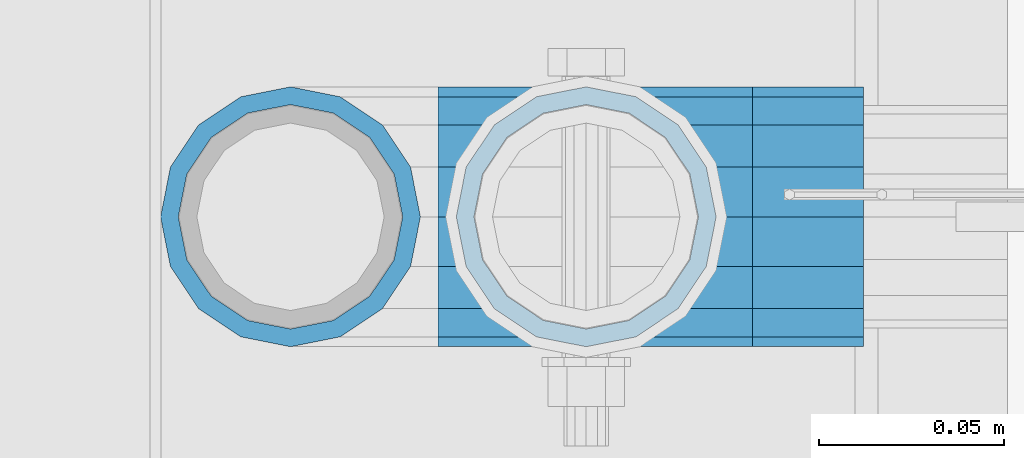
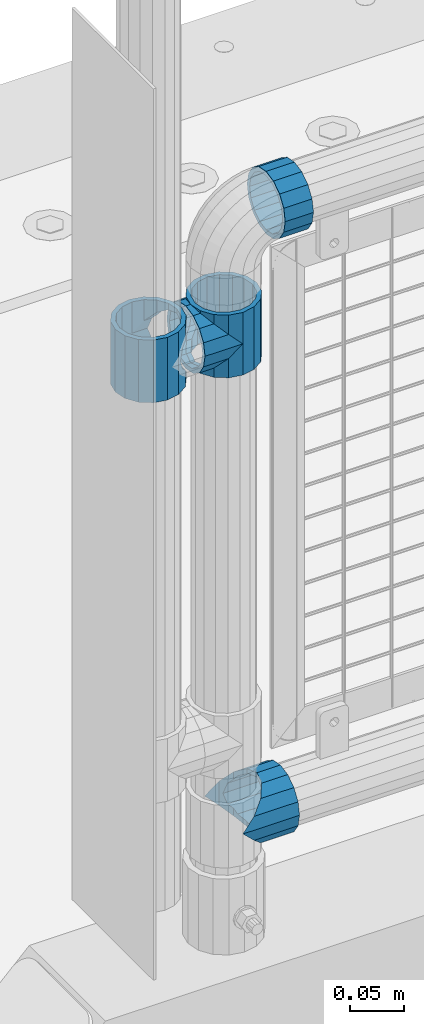
# One storey, part 159 of 270: 5 beams.
"""IFC2X3 building model written with IfcOpenShell, lengths in millimetres."""

from ifc_helpers import new_model, si_unit, frame, origin_with_axes, place, context, subcontext, project, spatial, faceted_brep, material, type_object, element, save


model = new_model("IFC2X3")

# Units and contexts
model_context = context("Model", 3, precision=1e-05, world=origin_with_axes())
body_context = subcontext(model_context, "Body", "Model", "MODEL_VIEW")
ifc_project = project(units=[si_unit("LENGTHUNIT", "METRE", prefix="MILLI"), si_unit("AREAUNIT", "SQUARE_METRE"), si_unit("VOLUMEUNIT", "CUBIC_METRE"), si_unit("MASSUNIT", "GRAM", prefix="KILO"), si_unit("TIMEUNIT", "SECOND"), si_unit("PLANEANGLEUNIT", "RADIAN"), si_unit("SOLIDANGLEUNIT", "STERADIAN"), si_unit("THERMODYNAMICTEMPERATUREUNIT", "DEGREE_CELSIUS"), si_unit("LUMINOUSINTENSITYUNIT", "LUMEN")], contexts=[model_context])

# Site, building, storey
site_placement = place(None, origin_with_axes())
site = spatial("IfcSite", under=ifc_project, at=site_placement, CompositionType="ELEMENT")
building_placement = place(site_placement, origin_with_axes())
building = spatial("IfcBuilding", under=site, at=building_placement, Name="Standard", CompositionType="ELEMENT")
storey_placement = place(building_placement, origin_with_axes())
storey = spatial("IfcBuildingStorey", under=building, at=storey_placement, Name="Undefined", CompositionType="ELEMENT", Elevation=0.0)

# Beams
ifc_material = material(Name="Misc_Undefined")
beam_type = type_object("IfcBeamType", PredefinedType="NOTDEFINED")
beam_1_placement = place(storey_placement, frame((621.0, -16335.5, 848.670000000001), z_axis=(0.0, 1.0, 0.0), x_axis=(-1.0, 0.0, 0.0)))
element("IfcBeam", 1, at=beam_1_placement, inside=storey, type_object=beam_type, material=ifc_material, context=body_context, shape_type="Brep", body=[
    faceted_brep([(0.0, 0.0, -35.1499999999996), (13.4513226476338, -13.4513226476329, -32.4743655677721), (13.4513226476338, 13.4513226476329, -32.4743655677721), (32.4743655677703, -26.8123795176775, 13.4513226476338), (32.4743655677703, -32.4743655677717, 13.4513226476338), (24.8548033587067, -24.8548033587072, 24.8548033587067), (24.8548033587067, -16.3810424080045, 24.8548033587067), (27.1226768591041, -21.4606908090117, 21.4606908090118), (35.1500000000015, -30.35, 0.0), (35.1500000000015, -35.15, 0.0), (32.8397438117208, -28.0397438117175, 11.6144421722802), (32.8397438117172, -28.0397438117175, -11.6144421722802), (32.4743655677703, -26.8123795176776, -13.4513226476338), (32.4743655677703, -32.4743655677717, -13.4513226476338), (27.1226768591041, -21.4606908090117, -21.4606908090118), (24.8548033587067, -16.3810424080045, -24.8548033587067), (24.8548033587067, -24.8548033587072, -24.8548033587067), (20.0882031229849, -11.6144421722805, -28.0397438117179), (16.6306603983721, 0.0, -30.3500000000004), (20.0882031229849, 11.6144421722805, -28.0397438117179), (24.8548033587067, 16.3810424080045, -24.8548033587067), (24.8548033587067, 24.8548033587072, -24.8548033587067), (27.1226768591041, 21.4606908090117, -21.4606908090118), (32.4743655677703, 26.8123795176775, -13.4513226476338), (32.4743655677703, 32.4743655677717, -13.4513226476338), (32.8397438117172, 28.0397438117175, -11.6144421722802), (35.1500000000015, 30.35, 0.0), (35.1500000000015, 35.1500000000003, 0.0), (32.8397438117208, 28.0397438117175, 11.6144421722802), (32.4743655677703, 26.8123795176776, 13.4513226476338), (32.4743655677703, 32.4743655677717, 13.4513226476338), (27.1226768591041, 21.4606908090117, 21.4606908090118), (24.8548033587067, 16.3810424080045, 24.8548033587067), (24.8548033587067, 24.8548033587072, 24.8548033587067), (13.4513226476338, 13.4513226476329, 32.4743655677721), (13.4513226476338, -13.4513226476329, 32.4743655677721), (0.0, 0.0, 35.1499999999996), (20.0882031229812, 11.6144421722805, 28.0397438117179), (16.6306603983612, 0.0, 30.3500000000004), (20.0882031229812, -11.6144421722805, 28.0397438117179), (40.1500000000015, -35.15, 0.0), (40.1500000000015, -32.4743655677717, 13.4513226476338), (40.1500000000015, -24.8548033587072, 24.8548033587067), (40.1500000000015, -13.4513226476329, 32.4743655677721), (40.1500000000015, 0.0, 35.1499999999996), (40.1500000000015, -24.8548033587072, -24.8548033587067), (40.1500000000015, -32.4743655677717, -13.4513226476338), (40.1500000000015, -13.4513226476329, -32.4743655677721), (40.1500000000015, 0.0, -35.1499999999996), (40.1500000000015, 13.4513226476329, -32.4743655677721), (40.1500000000015, 24.8548033587072, -24.8548033587067), (40.1500000000015, 32.4743655677717, -13.4513226476338), (40.1500000000015, 35.15, 0.0), (40.1500000000015, 32.4743655677717, 13.4513226476338), (40.1500000000015, 24.8548033587072, 24.8548033587067), (40.1500000000015, 13.4513226476329, 32.4743655677721), (40.1500000000015, -21.4606908090117, 21.4606908090118), (40.1500000000015, -11.6144421722805, 28.0397438117179), (40.1500000000015, 0.0, 30.3500000000004), (40.1500000000015, 11.6144421722805, 28.0397438117179), (40.1500000000015, 21.4606908090117, 21.4606908090118), (40.1500000000015, 28.0397438117175, 11.6144421722802), (40.1500000000015, 30.35, 0.0), (40.1500000000015, 28.0397438117175, -11.6144421722802), (40.1500000000015, 21.4606908090117, -21.4606908090118), (40.1500000000015, 11.6144421722805, -28.0397438117179), (40.1500000000015, 0.0, -30.3500000000004), (40.1500000000015, -11.6144421722805, -28.0397438117179), (40.1500000000015, -21.4606908090117, -21.4606908090118), (40.1500000000015, -28.0397438117175, -11.6144421722802), (40.1500000000015, -30.35, 0.0), (40.1500000000015, -28.0397438117175, 11.6144421722802)], [[[0, 1, 2]], [[3, 4, 5, 6, 7]], [[8, 9, 4, 3, 10]], [[11, 12, 13, 9, 8]], [[14, 15, 16, 13, 12]], [[2, 1, 16, 15, 17, 18, 19, 20, 21]], [[21, 20, 22, 23, 24]], [[24, 23, 25, 26, 27]], [[27, 26, 28, 29, 30]], [[30, 29, 31, 32, 33]], [[34, 35, 36]], [[33, 32, 37, 38, 39, 6, 5, 35, 34]], [[40, 41, 4, 9]], [[41, 42, 5, 4]], [[42, 43, 35, 5]], [[43, 44, 36, 35]], [[45, 46, 13, 16]], [[47, 45, 16, 1]], [[48, 47, 1, 0]], [[49, 48, 0, 2]], [[50, 49, 2, 21]], [[51, 50, 21, 24]], [[52, 51, 24, 27]], [[53, 52, 27, 30]], [[54, 53, 30, 33]], [[55, 54, 33, 34]], [[44, 55, 34, 36]], [[46, 40, 9, 13]], [[45, 47, 48, 49, 50, 51, 52, 53, 54, 55, 44, 43, 42, 41, 40, 46], [56, 57, 58, 59, 60, 61, 62, 63, 64, 65, 66, 67, 68, 69, 70, 71]], [[59, 58, 38, 37]], [[60, 59, 37, 32, 31]], [[61, 60, 31, 29, 28]], [[62, 61, 28, 26]], [[63, 62, 26, 25]], [[22, 64, 63, 25, 23]], [[19, 65, 64, 22, 20]], [[66, 65, 19, 18]], [[67, 66, 18, 17]], [[68, 67, 17, 15, 14]], [[69, 68, 14, 12, 11]], [[70, 69, 11, 8]], [[71, 70, 8, 10]], [[7, 56, 71, 10, 3]], [[39, 57, 56, 7, 6]], [[58, 57, 39, 38]]]),
])
beam_2_placement = place(storey_placement, frame((541.0, -16335.5, 883.82), z_axis=(-1.0, 0.0, 0.0), x_axis=(0.0, 0.0, -1.0)))
element("IfcBeam", 2, at=beam_2_placement, inside=storey, type_object=beam_type, material=ifc_material, context=body_context, shape_type="Brep", body=[
    faceted_brep([(7.11025618828319, -11.6144421722802, -32.8397438117172), (7.11025618828319, -11.6144421722802, -28.0397438117179), (13.689309190989, -21.4606908090118, -21.46069080901), (13.689309190989, -21.4606908090118, -27.1226768591041), (8.33762048232484, -13.4513226476338, -32.4743655677703), (23.5355578277203, -28.0397438117179, -11.614442172282), (23.5355578277203, -28.0397438117179, -20.0882031229885), (18.7689575919954, -24.8548033587067, -24.8548033587067), (35.1500000000015, -30.35, 0.0), (35.1500000000008, -30.3500000000004, -16.6306603983721), (46.7644421722812, -28.0397438117179, -11.614442172282), (46.7644421722812, -28.0397438117179, -20.0882031229885), (51.5310424080071, -24.8548033587067, -24.8548033587067), (56.6106908090125, -21.4606908090118, -21.46069080901), (56.6106908090125, -21.4606908090118, -27.1226768591041), (61.9623795176767, -13.4513226476338, -32.4743655677703), (63.1897438117183, -11.6144421722802, -28.0397438117179), (63.1897438117183, -11.6144421722802, -32.8397438117172), (65.5000000000008, 0.0, -30.3499999999985), (65.5000000000008, 0.0, -35.1500000000015), (63.1897438117183, 11.6144421722802, -28.0397438117179), (63.1897438117183, 11.6144421722802, -32.8397438117208), (56.6106908090125, 21.4606908090118, -21.46069080901), (56.6106908090125, 21.4606908090118, -27.1226768591005), (61.9623795176767, 13.4513226476338, -32.4743655677703), (46.7644421722812, 28.0397438117179, -11.614442172282), (46.7644421722812, 28.0397438117179, -20.0882031229812), (51.5310424080071, 24.8548033587067, -24.8548033587067), (35.1500000000015, 30.35, 0.0), (35.1500000000008, 30.3500000000004, -16.6306603983612), (23.5355578277203, 28.0397438117179, -11.614442172282), (23.5355578277203, 28.0397438117179, -20.0882031229812), (18.7689575919954, 24.8548033587067, -24.8548033587067), (13.689309190989, 21.4606908090118, -21.46069080901), (13.689309190989, 21.4606908090118, -27.1226768591005), (8.33762048232484, 13.4513226476338, -32.4743655677703), (7.11025618828324, 11.6144421722802, -28.0397438117179), (7.11025618828324, 11.6144421722802, -32.8397438117208), (4.80000000000075, 0.0, -30.3499999999985), (4.80000000000075, 0.0, -35.1500000000015), (0.0, 21.4606908090118, 21.46069080901), (0.0, 28.0397438117179, 11.614442172282), (70.2999999999993, 28.0397438117179, 11.614442172282), (70.2999999999993, 21.4606908090118, 21.46069080901), (0.0, 11.6144421722802, 28.0397438117179), (70.2999999999993, 11.6144421722802, 28.0397438117179), (0.0, 0.0, 30.3499999999985), (70.2999999999993, 0.0, 30.3499999999985), (0.0, -11.6144421722802, 28.0397438117179), (70.2999999999993, -11.6144421722802, 28.0397438117179), (0.0, -21.4606908090118, 21.46069080901), (70.2999999999993, -21.4606908090118, 21.46069080901), (0.0, -28.0397438117179, 11.614442172282), (70.2999999999993, -28.0397438117179, 11.614442172282), (0.0, -24.8548033587067, -24.8548033587067), (0.0, -13.4513226476338, -32.4743655677703), (0.0, 0.0, -35.1499999999996), (0.0, -32.4743655677721, 13.4513226476338), (0.0, -35.1499999999996, 0.0), (70.2999999999993, -35.1499999999996, 0.0), (70.2999999999993, -32.4743655677721, 13.4513226476338), (0.0, -24.8548033587067, 24.8548033587067), (70.2999999999993, -24.8548033587067, 24.8548033587067), (0.0, -13.4513226476338, 32.4743655677703), (70.2999999999993, -13.4513226476338, 32.4743655677703), (0.0, 0.0, 35.1499999999996), (70.2999999999993, 0.0, 35.1500000000015), (0.0, 13.4513226476338, 32.4743655677703), (70.2999999999993, 13.4513226476338, 32.4743655677703), (0.0, 24.8548033587067, 24.8548033587067), (70.2999999999993, 24.8548033587067, 24.8548033587067), (0.0, 32.4743655677721, 13.4513226476338), (70.2999999999993, 32.4743655677721, 13.4513226476338), (0.0, 35.1499999999996, 0.0), (70.2999999999993, 35.1499999999996, 0.0), (0.0, 32.4743655677721, -13.4513226476338), (70.2999999999993, 32.4743655677721, -13.4513226476338), (70.2999999999993, -13.4513226476338, -32.4743655677703), (70.2999999999993, -24.8548033587067, -24.8548033587067), (70.2999999999993, 0.0, -35.1500000000015), (70.2999999999993, 13.4513226476338, -32.4743655677703), (70.2999999999993, 24.8548033587067, -24.8548033587067), (0.0, 24.8548033587067, -24.8548033587067), (0.0, 13.4513226476338, -32.4743655677703), (70.2999999999993, -32.4743655677721, -13.4513226476338), (0.0, -32.4743655677721, -13.4513226476338), (0.0, -28.0397438117179, -11.614442172282), (0.0, -21.4606908090118, -21.46069080901), (0.0, -11.6144421722802, -28.0397438117179), (0.0, 0.0, -30.3499999999985), (0.0, 11.6144421722802, -28.0397438117179), (0.0, 21.4606908090118, -21.46069080901), (0.0, 28.0397438117179, -11.614442172282), (0.0, 30.3500000000004, 0.0), (0.0, -30.3500000000004, 0.0), (70.2999999999993, 30.3500000000004, 0.0), (70.2999999999993, 28.0397438117179, -11.614442172282), (70.2999999999993, 21.4606908090118, -21.46069080901), (70.2999999999993, 11.6144421722802, -28.0397438117179), (70.2999999999993, 0.0, -30.3499999999985), (70.2999999999993, -11.6144421722802, -28.0397438117179), (70.2999999999993, -21.4606908090118, -21.46069080901), (70.2999999999993, -28.0397438117179, -11.614442172282), (70.2999999999993, -30.3500000000004, 0.0)], [[[0, 1, 2, 3, 4]], [[3, 2, 5, 6, 7]], [[6, 5, 8, 9]], [[9, 8, 10, 11]], [[12, 11, 10, 13, 14]], [[15, 14, 13, 16, 17]], [[17, 16, 18, 19]], [[19, 18, 20, 21]], [[21, 20, 22, 23, 24]], [[23, 22, 25, 26, 27]], [[26, 25, 28, 29]], [[29, 28, 30, 31]], [[32, 31, 30, 33, 34]], [[35, 34, 33, 36, 37]], [[37, 36, 38, 39]], [[39, 38, 1, 0]], [[40, 41, 42, 43]], [[44, 40, 43, 45]], [[46, 44, 45, 47]], [[48, 46, 47, 49]], [[50, 48, 49, 51]], [[52, 50, 51, 53]], [[7, 54, 55, 4, 3]], [[4, 55, 56, 39, 0]], [[57, 58, 59, 60]], [[61, 57, 60, 62]], [[63, 61, 62, 64]], [[65, 63, 64, 66]], [[67, 65, 66, 68]], [[69, 67, 68, 70]], [[71, 69, 70, 72]], [[73, 71, 72, 74]], [[75, 73, 74, 76]], [[77, 78, 12, 14, 15]], [[79, 77, 15, 17, 19]], [[24, 80, 79, 19, 21]], [[27, 81, 80, 24, 23]], [[82, 75, 76, 81, 27, 26, 29, 31, 32]], [[83, 82, 32, 34, 35]], [[56, 83, 35, 37, 39]], [[9, 11, 12, 78, 84, 85, 54, 7, 6]], [[58, 85, 84, 59]], [[57, 61, 63, 65, 67, 69, 71, 73, 75, 82, 83, 56, 55, 54, 85, 58], [86, 87, 88, 89, 90, 91, 92, 93, 41, 40, 44, 46, 48, 50, 52, 94]], [[90, 89, 38, 36]], [[91, 90, 36, 33]], [[92, 91, 33, 30]], [[93, 92, 30, 28]], [[41, 93, 28, 95, 42]], [[96, 95, 28, 25]], [[97, 96, 25, 22]], [[98, 97, 22, 20]], [[99, 98, 20, 18]], [[100, 99, 18, 16]], [[101, 100, 16, 13]], [[102, 101, 13, 10]], [[103, 102, 10, 8]], [[78, 77, 79, 80, 81, 76, 74, 72, 70, 68, 66, 64, 62, 60, 59, 84], [51, 49, 47, 45, 43, 42, 95, 96, 97, 98, 99, 100, 101, 102, 103, 53]], [[8, 94, 52, 53, 103]], [[86, 94, 8, 5]], [[87, 86, 5, 2]], [[88, 87, 2, 1]], [[89, 88, 1, 38]]]),
])
beam_3_placement = place(storey_placement, frame((621.0, -16335.5, 883.82), z_axis=(1.0, 0.0, 0.0), x_axis=(0.0, 0.0, -1.0)))
element("IfcBeam", 3, at=beam_3_placement, inside=storey, type_object=beam_type, material=ifc_material, context=body_context, shape_type="Brep", body=[
    faceted_brep([(56.6106908090125, 21.4606908090118, -27.1226768591005), (56.6106908090125, 21.4606908090118, -21.46069080901), (46.7644421722812, 28.0397438117179, -11.614442172282), (46.7644421722812, 28.0397438117179, -20.0882031229812), (51.5310424080071, 24.8548033587067, -24.8548033587067), (63.1897438117183, 11.6144421722802, -32.8397438117208), (63.1897438117183, 11.6144421722802, -28.0397438117179), (61.9623795176767, 13.4513226476338, -32.4743655677703), (65.5000000000008, 0.0, -35.1500000000015), (65.5000000000008, 0.0, -30.3499999999985), (63.1897438117183, -11.6144421722802, -32.8397438117172), (63.1897438117183, -11.6144421722802, -28.0397438117179), (61.9623795176767, -13.4513226476338, -32.4743655677703), (56.6106908090125, -21.4606908090118, -27.1226768591041), (56.6106908090125, -21.4606908090118, -21.46069080901), (51.5310424080071, -24.8548033587067, -24.8548033587067), (46.7644421722812, -28.0397438117179, -20.0882031229885), (46.7644421722812, -28.0397438117179, -11.614442172282), (35.1500000000008, -30.3500000000004, -16.6306603983721), (35.1500000000015, -30.35, 0.0), (23.5355578277203, -28.0397438117179, -20.0882031229885), (23.5355578277203, -28.0397438117179, -11.614442172282), (13.689309190989, -21.4606908090118, -27.1226768591041), (13.689309190989, -21.4606908090118, -21.46069080901), (18.7689575919954, -24.8548033587067, -24.8548033587067), (7.11025618828319, -11.6144421722802, -32.8397438117172), (7.11025618828319, -11.6144421722802, -28.0397438117179), (8.33762048232484, -13.4513226476338, -32.4743655677703), (4.80000000000075, 0.0, -35.1500000000015), (4.80000000000075, 0.0, -30.3499999999985), (7.11025618828324, 11.6144421722802, -32.8397438117208), (7.11025618828324, 11.6144421722802, -28.0397438117179), (8.33762048232484, 13.4513226476338, -32.4743655677703), (13.689309190989, 21.4606908090118, -27.1226768591005), (13.689309190989, 21.4606908090118, -21.46069080901), (18.7689575919954, 24.8548033587067, -24.8548033587067), (23.5355578277203, 28.0397438117179, -20.0882031229812), (23.5355578277203, 28.0397438117179, -11.614442172282), (35.1500000000008, 30.3500000000004, -16.6306603983612), (35.1500000000015, 30.35, 0.0), (0.0, 32.4743655677721, -13.4513226476338), (0.0, 35.1499999999996, 0.0), (70.2999999999993, 35.1499999999996, 0.0), (70.2999999999993, 32.4743655677721, -13.4513226476338), (0.0, 32.4743655677721, 13.4513226476338), (70.2999999999993, 32.4743655677721, 13.4513226476338), (0.0, 24.8548033587067, 24.8548033587067), (70.2999999999993, 24.8548033587067, 24.8548033587067), (0.0, 13.4513226476338, 32.4743655677703), (70.2999999999993, 13.4513226476338, 32.4743655677703), (0.0, 0.0, 35.1499999999996), (70.2999999999993, 0.0, 35.1500000000015), (0.0, -13.4513226476338, 32.4743655677703), (70.2999999999993, -13.4513226476338, 32.4743655677703), (0.0, -24.8548033587067, 24.8548033587067), (70.2999999999993, -24.8548033587067, 24.8548033587067), (0.0, -32.4743655677721, 13.4513226476338), (70.2999999999993, -32.4743655677721, 13.4513226476338), (0.0, -35.1499999999996, 0.0), (70.2999999999993, -35.1499999999996, 0.0), (70.2999999999993, -30.3500000000004, 0.0), (70.2999999999993, -28.0397438117179, -11.614442172282), (70.2999999999993, -21.4606908090118, -21.46069080901), (70.2999999999993, -11.6144421722802, -28.0397438117179), (70.2999999999993, 0.0, -30.3499999999985), (70.2999999999993, 11.6144421722802, -28.0397438117179), (70.2999999999993, 21.4606908090118, -21.46069080901), (70.2999999999993, 28.0397438117179, -11.614442172282), (0.0, -28.0397438117179, -11.614442172282), (0.0, -30.3500000000004, 0.0), (0.0, -21.4606908090118, -21.46069080901), (0.0, -11.6144421722802, -28.0397438117179), (0.0, 0.0, -30.3499999999985), (0.0, 11.6144421722802, -28.0397438117179), (0.0, 21.4606908090118, -21.46069080901), (0.0, 28.0397438117179, -11.614442172282), (0.0, 30.3500000000004, 0.0), (70.2999999999993, 30.3500000000004, 0.0), (0.0, 28.0397438117179, 11.614442172282), (70.2999999999993, 28.0397438117179, 11.614442172282), (0.0, 21.4606908090118, 21.46069080901), (70.2999999999993, 21.4606908090118, 21.46069080901), (0.0, 11.6144421722802, 28.0397438117179), (70.2999999999993, 11.6144421722802, 28.0397438117179), (0.0, 0.0, 30.3499999999985), (70.2999999999993, 0.0, 30.3499999999985), (0.0, -11.6144421722802, 28.0397438117179), (70.2999999999993, -11.6144421722802, 28.0397438117179), (0.0, -21.4606908090118, 21.46069080901), (70.2999999999993, -21.4606908090118, 21.46069080901), (0.0, -28.0397438117179, 11.614442172282), (70.2999999999993, -28.0397438117179, 11.614442172282), (70.2999999999993, -24.8548033587067, -24.8548033587067), (70.2999999999993, -13.4513226476338, -32.4743655677703), (70.2999999999993, 0.0, -35.1500000000015), (70.2999999999993, 13.4513226476338, -32.4743655677703), (70.2999999999993, 24.8548033587067, -24.8548033587067), (70.2999999999993, -32.4743655677721, -13.4513226476338), (0.0, -32.4743655677721, -13.4513226476338), (0.0, 24.8548033587067, -24.8548033587067), (0.0, 13.4513226476338, -32.4743655677703), (0.0, 0.0, -35.1499999999996), (0.0, -13.4513226476338, -32.4743655677703), (0.0, -24.8548033587067, -24.8548033587067)], [[[0, 1, 2, 3, 4]], [[5, 6, 1, 0, 7]], [[8, 9, 6, 5]], [[10, 11, 9, 8]], [[12, 13, 14, 11, 10]], [[15, 16, 17, 14, 13]], [[18, 19, 17, 16]], [[20, 21, 19, 18]], [[22, 23, 21, 20, 24]], [[25, 26, 23, 22, 27]], [[28, 29, 26, 25]], [[30, 31, 29, 28]], [[32, 33, 34, 31, 30]], [[35, 36, 37, 34, 33]], [[38, 39, 37, 36]], [[3, 2, 39, 38]], [[40, 41, 42, 43]], [[41, 44, 45, 42]], [[44, 46, 47, 45]], [[46, 48, 49, 47]], [[48, 50, 51, 49]], [[50, 52, 53, 51]], [[52, 54, 55, 53]], [[54, 56, 57, 55]], [[56, 58, 59, 57]], [[60, 61, 17, 19]], [[61, 62, 14, 17]], [[62, 63, 11, 14]], [[63, 64, 9, 11]], [[64, 65, 6, 9]], [[65, 66, 1, 6]], [[66, 67, 2, 1]], [[68, 69, 19, 21]], [[70, 68, 21, 23]], [[71, 70, 23, 26]], [[72, 71, 26, 29]], [[73, 72, 29, 31]], [[74, 73, 31, 34]], [[75, 74, 34, 37]], [[76, 75, 37, 39]], [[67, 77, 39, 2]], [[78, 76, 39, 77, 79]], [[80, 78, 79, 81]], [[82, 80, 81, 83]], [[84, 82, 83, 85]], [[86, 84, 85, 87]], [[88, 86, 87, 89]], [[90, 88, 89, 91]], [[19, 69, 90, 91, 60]], [[92, 93, 94, 95, 96, 43, 42, 45, 47, 49, 51, 53, 55, 57, 59, 97], [89, 87, 85, 83, 81, 79, 77, 67, 66, 65, 64, 63, 62, 61, 60, 91]], [[58, 98, 97, 59]], [[56, 54, 52, 50, 48, 46, 44, 41, 40, 99, 100, 101, 102, 103, 98, 58], [68, 70, 71, 72, 73, 74, 75, 76, 78, 80, 82, 84, 86, 88, 90, 69]], [[100, 99, 35, 33, 32]], [[101, 100, 32, 30, 28]], [[27, 102, 101, 28, 25]], [[24, 103, 102, 27, 22]], [[18, 16, 15, 92, 97, 98, 103, 24, 20]], [[93, 92, 15, 13, 12]], [[94, 93, 12, 10, 8]], [[7, 95, 94, 8, 5]], [[4, 96, 95, 7, 0]], [[99, 40, 43, 96, 4, 3, 38, 36, 35]]]),
])
beam_4_placement = place(storey_placement, frame((621.0, -16335.5, 298.67), z_axis=(0.0, 1.0, 0.0), x_axis=(1.0, 0.0, 0.0)))
element("IfcBeam", 4, at=beam_4_placement, inside=storey, type_object=beam_type, material=ifc_material, context=body_context, shape_type="Brep", body=[
    faceted_brep([(13.4513226476338, 13.4513226476329, 32.4743655677721), (13.4513226476338, -13.4513226476329, 32.4743655677721), (0.0, 0.0, 35.1499999999996), (27.1226768591041, -21.4606908090117, -21.4606908090118), (24.8548033587067, -16.3810424080045, -24.8548033587067), (24.8548033587067, -24.8548033587072, -24.8548033587067), (32.4743655677703, -32.4743655677717, -13.4513226476338), (32.4743655677703, -26.8123795176776, -13.4513226476338), (0.0, 0.0, -35.1499999999996), (13.4513226476338, -13.4513226476329, -32.4743655677721), (13.4513226476338, 13.4513226476329, -32.4743655677721), (20.0882031229849, -11.6144421722805, -28.0397438117179), (16.6306603983721, 0.0, -30.3500000000004), (20.0882031229849, 11.6144421722805, -28.0397438117179), (24.8548033587067, 16.3810424080045, -24.8548033587067), (24.8548033587067, 24.8548033587072, -24.8548033587067), (27.1226768591041, 21.4606908090117, -21.4606908090118), (32.4743655677703, 26.8123795176775, -13.4513226476338), (32.4743655677703, 32.4743655677717, -13.4513226476338), (32.8397438117172, 28.0397438117175, -11.6144421722802), (35.1500000000015, 30.35, 0.0), (35.1500000000015, 35.1500000000003, 0.0), (32.8397438117208, 28.0397438117175, 11.6144421722802), (32.4743655677703, 26.8123795176776, 13.4513226476338), (32.4743655677703, 32.4743655677717, 13.4513226476338), (27.1226768591041, 21.4606908090117, 21.4606908090118), (24.8548033587067, 16.3810424080045, 24.8548033587067), (24.8548033587067, 24.8548033587072, 24.8548033587067), (20.0882031229812, 11.6144421722805, 28.0397438117179), (16.6306603983612, 0.0, 30.3500000000004), (20.0882031229812, -11.6144421722805, 28.0397438117179), (24.8548033587067, -16.3810424080045, 24.8548033587067), (24.8548033587067, -24.8548033587072, 24.8548033587067), (32.4743655677703, -26.8123795176775, 13.4513226476338), (32.4743655677703, -32.4743655677717, 13.4513226476338), (27.1226768591041, -21.4606908090117, 21.4606908090118), (35.1500000000015, -30.35, 0.0), (35.1500000000015, -35.15, 0.0), (32.8397438117208, -28.0397438117175, 11.6144421722802), (32.8397438117172, -28.0397438117175, -11.6144421722802), (60.1500000000015, -24.8548033587072, -24.8548033587067), (60.1500000000015, -32.4743655677717, -13.4513226476338), (60.1500000000015, -13.4513226476329, -32.4743655677721), (60.1499999999978, 0.0, -35.1499999999996), (60.1500000000015, 13.4513226476329, -32.4743655677721), (60.1500000000015, 24.8548033587072, -24.8548033587067), (60.1500000000015, 32.4743655677717, -13.4513226476338), (60.1500000000015, 35.15, 0.0), (60.1500000000015, 32.4743655677717, 13.4513226476338), (60.1500000000015, 24.8548033587072, 24.8548033587067), (60.1500000000015, 13.4513226476329, 32.4743655677721), (60.1499999999978, 0.0, 35.1499999999996), (60.1500000000015, -13.4513226476329, 32.4743655677721), (60.1500000000015, -24.8548033587072, 24.8548033587067), (60.1500000000015, -32.4743655677717, 13.4513226476338), (60.1500000000015, -35.15, 0.0), (60.1500000000015, -21.4606908090117, 21.4606908090118), (60.1500000000015, -11.6144421722805, 28.0397438117179), (60.1500000000015, 0.0, 30.3500000000004), (60.1500000000015, 11.6144421722805, 28.0397438117179), (60.1500000000015, 21.4606908090117, 21.4606908090118), (60.1500000000015, 28.0397438117175, 11.6144421722802), (60.1500000000015, 30.35, 0.0), (60.1500000000015, 28.0397438117175, -11.6144421722802), (60.1500000000015, 21.4606908090117, -21.4606908090118), (60.1500000000015, 11.6144421722805, -28.0397438117179), (60.1500000000015, 0.0, -30.3500000000004), (60.1500000000015, -11.6144421722805, -28.0397438117179), (60.1500000000015, -21.4606908090117, -21.4606908090118), (60.1500000000015, -28.0397438117175, -11.6144421722802), (60.1500000000015, -30.35, 0.0), (60.1500000000015, -28.0397438117175, 11.6144421722802)], [[[0, 1, 2]], [[3, 4, 5, 6, 7]], [[8, 9, 10]], [[10, 9, 5, 4, 11, 12, 13, 14, 15]], [[15, 14, 16, 17, 18]], [[18, 17, 19, 20, 21]], [[21, 20, 22, 23, 24]], [[24, 23, 25, 26, 27]], [[27, 26, 28, 29, 30, 31, 32, 1, 0]], [[33, 34, 32, 31, 35]], [[36, 37, 34, 33, 38]], [[39, 7, 6, 37, 36]], [[40, 41, 6, 5]], [[42, 40, 5, 9]], [[43, 42, 9, 8]], [[44, 43, 8, 10]], [[45, 44, 10, 15]], [[46, 45, 15, 18]], [[47, 46, 18, 21]], [[48, 47, 21, 24]], [[49, 48, 24, 27]], [[50, 49, 27, 0]], [[51, 50, 0, 2]], [[52, 51, 2, 1]], [[53, 52, 1, 32]], [[54, 53, 32, 34]], [[55, 54, 34, 37]], [[41, 55, 37, 6]], [[40, 42, 43, 44, 45, 46, 47, 48, 49, 50, 51, 52, 53, 54, 55, 41], [56, 57, 58, 59, 60, 61, 62, 63, 64, 65, 66, 67, 68, 69, 70, 71]], [[71, 70, 36, 38]], [[35, 56, 71, 38, 33]], [[30, 57, 56, 35, 31]], [[58, 57, 30, 29]], [[59, 58, 29, 28]], [[60, 59, 28, 26, 25]], [[61, 60, 25, 23, 22]], [[62, 61, 22, 20]], [[63, 62, 20, 19]], [[16, 64, 63, 19, 17]], [[13, 65, 64, 16, 14]], [[66, 65, 13, 12]], [[67, 66, 12, 11]], [[68, 67, 11, 4, 3]], [[69, 68, 3, 7, 39]], [[70, 69, 39, 36]]]),
])
beam_5_placement = place(storey_placement, frame((666.0, -16335.5, 969.849999999999), z_axis=(0.0, 0.0, 1.0), x_axis=(1.0, 0.0, 0.0)))
element("IfcBeam", 5, at=beam_5_placement, inside=storey, type_object=beam_type, material=ifc_material, context=body_context, shape_type="Brep", body=[
    faceted_brep([(0.0, -30.3500000000004, 0.0), (0.0, -28.0397438117179, 11.614442172282), (30.0, -28.0397438117179, 11.6144421722805), (30.0, -30.3500000000004, 0.0), (0.0, -21.4606908090118, 21.46069080901), (30.0, -21.4606908090118, 21.4606908090117), (0.0, -11.6144421722802, 28.0397438117179), (30.0, -11.6144421722802, 28.0397438117176), (0.0, 0.0, 30.3499999999985), (30.0, 0.0, 30.35), (0.0, 11.6144421722802, 28.0397438117179), (30.0, 11.6144421722802, 28.0397438117176), (0.0, 21.4606908090118, 21.46069080901), (30.0, 21.4606908090118, 21.4606908090117), (0.0, 28.0397438117179, 11.614442172282), (30.0, 28.0397438117179, 11.6144421722805), (0.0, 30.3500000000004, 0.0), (30.0, 30.3500000000004, 0.0), (0.0, 28.0397438117179, -11.614442172282), (30.0, 28.0397438117179, -11.6144421722805), (0.0, 21.4606908090118, -21.46069080901), (30.0, 21.4606908090118, -21.4606908090117), (0.0, 11.6144421722802, -28.0397438117179), (30.0, 11.6144421722802, -28.0397438117176), (0.0, 0.0, -30.3499999999985), (30.0, 0.0, -30.35), (0.0, -11.6144421722802, -28.0397438117179), (30.0, -11.6144421722802, -28.0397438117176), (0.0, -21.4606908090118, -21.46069080901), (30.0, -21.4606908090118, -21.4606908090117), (0.0, -28.0397438117179, -11.614442172282), (30.0, -28.0397438117179, -11.6144421722805), (0.0, -35.1499999999996, 0.0), (0.0, -32.4743655677721, -13.4513226476338), (30.0, -32.4743655677721, -13.4513226476329), (30.0, -35.1499999999996, 0.0), (0.0, -24.8548033587067, -24.8548033587067), (30.0, -24.8548033587067, -24.8548033587072), (0.0, -13.4513226476338, -32.4743655677703), (30.0, -13.4513226476338, -32.4743655677718), (0.0, 0.0, -35.1499999999996), (30.0, 0.0, -35.15), (0.0, 13.4513226476338, -32.4743655677703), (30.0, 13.4513226476338, -32.4743655677718), (0.0, 24.8548033587067, -24.8548033587067), (30.0, 24.8548033587067, -24.8548033587072), (0.0, 32.4743655677721, -13.4513226476338), (30.0, 32.4743655677721, -13.4513226476329), (0.0, 35.1499999999996, 0.0), (30.0, 35.1499999999996, 0.0), (0.0, 32.4743655677721, 13.4513226476338), (30.0, 32.4743655677721, 13.4513226476329), (0.0, 24.8548033587067, 24.8548033587067), (30.0, 24.8548033587067, 24.8548033587072), (0.0, 13.4513226476338, 32.4743655677703), (30.0, 13.4513226476338, 32.4743655677718), (0.0, 0.0, 35.1499999999996), (30.0, 0.0, 35.15), (0.0, -13.4513226476338, 32.4743655677703), (30.0, -13.4513226476338, 32.4743655677718), (0.0, -24.8548033587067, 24.8548033587067), (30.0, -24.8548033587067, 24.8548033587072), (0.0, -32.4743655677721, 13.4513226476338), (30.0, -32.4743655677721, 13.4513226476329)], [[[0, 1, 2, 3]], [[1, 4, 5, 2]], [[4, 6, 7, 5]], [[6, 8, 9, 7]], [[8, 10, 11, 9]], [[10, 12, 13, 11]], [[12, 14, 15, 13]], [[14, 16, 17, 15]], [[16, 18, 19, 17]], [[18, 20, 21, 19]], [[20, 22, 23, 21]], [[22, 24, 25, 23]], [[24, 26, 27, 25]], [[26, 28, 29, 27]], [[28, 30, 31, 29]], [[30, 0, 3, 31]], [[32, 33, 34, 35]], [[33, 36, 37, 34]], [[36, 38, 39, 37]], [[38, 40, 41, 39]], [[40, 42, 43, 41]], [[42, 44, 45, 43]], [[44, 46, 47, 45]], [[46, 48, 49, 47]], [[48, 50, 51, 49]], [[50, 52, 53, 51]], [[52, 54, 55, 53]], [[54, 56, 57, 55]], [[56, 58, 59, 57]], [[58, 60, 61, 59]], [[60, 62, 63, 61]], [[62, 32, 35, 63]], [[37, 39, 41, 43, 45, 47, 49, 51, 53, 55, 57, 59, 61, 63, 35, 34], [5, 7, 9, 11, 13, 15, 17, 19, 21, 23, 25, 27, 29, 31, 3, 2]], [[62, 60, 58, 56, 54, 52, 50, 48, 46, 44, 42, 40, 38, 36, 33, 32], [30, 28, 26, 24, 22, 20, 18, 16, 14, 12, 10, 8, 6, 4, 1, 0]]]),
])

save(model, "model.ifc")
